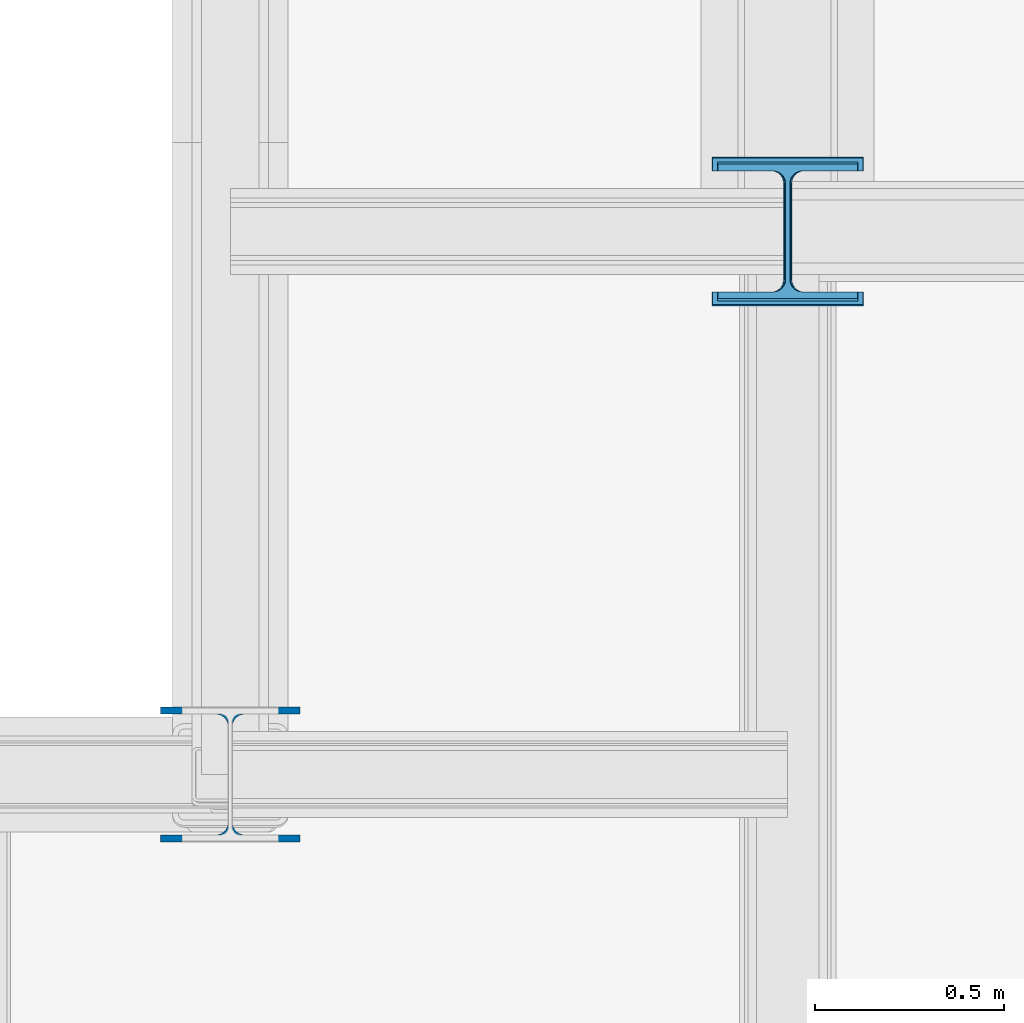
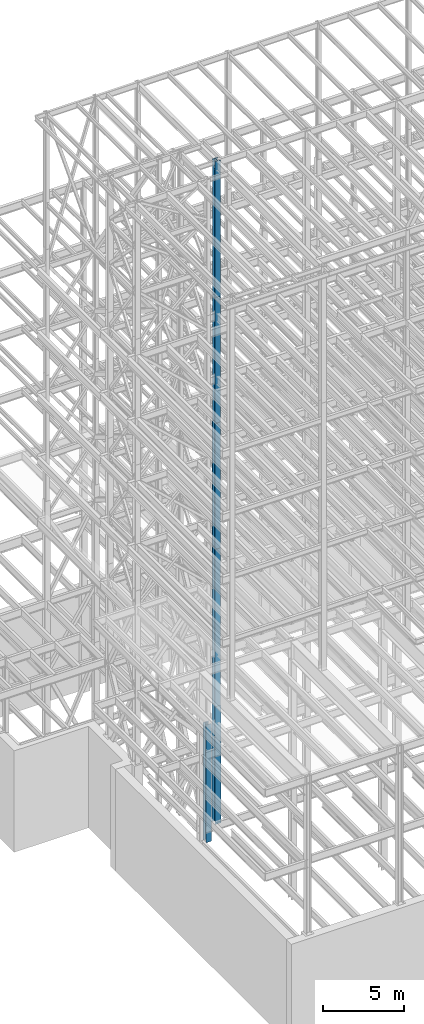
# One storey, part 12 of 150: 6 columns.
"""IFC2X3 building model written with IfcOpenShell, lengths in millimetres."""

from ifc_helpers import new_model, si_unit, frame, origin_with_axes, origin_2d_with_axis, place, context, subcontext, project, spatial, i_section, extrude, material, type_object, element, save


model = new_model("IFC2X3")

# Units and contexts
model_context = context("Model", 3, precision=1e-05, world=origin_with_axes())
body_context = subcontext(model_context, "Body", "Model", "MODEL_VIEW")
ifc_project = project(units=[si_unit("LENGTHUNIT", "METRE", prefix="MILLI"), si_unit("AREAUNIT", "SQUARE_METRE"), si_unit("VOLUMEUNIT", "CUBIC_METRE"), si_unit("MASSUNIT", "GRAM", prefix="KILO"), si_unit("TIMEUNIT", "SECOND"), si_unit("PLANEANGLEUNIT", "RADIAN"), si_unit("SOLIDANGLEUNIT", "STERADIAN"), si_unit("THERMODYNAMICTEMPERATUREUNIT", "DEGREE_CELSIUS"), si_unit("LUMINOUSINTENSITYUNIT", "LUMEN")], contexts=[model_context])

# Site, building, storey
site_placement = place(None, origin_with_axes())
site = spatial("IfcSite", under=ifc_project, at=site_placement, CompositionType="ELEMENT")
building_placement = place(site_placement, origin_with_axes())
building = spatial("IfcBuilding", under=site, at=building_placement, Name="Undefined", CompositionType="ELEMENT")
storey_placement = place(building_placement, origin_with_axes())
storey = spatial("IfcBuildingStorey", under=building, at=storey_placement, Name="Undefined", CompositionType="ELEMENT", Elevation=0.0)

# Columns
ifc_material = material(Name="STEEL/A992")
column_type_1 = type_object("IfcColumnType", Name="W14X193", PredefinedType="NOTDEFINED")
column_1_placement = place(storey_placement, frame((11785.6, 22479.0, 16154.4), z_axis=(0.0, 0.0, 1.0), x_axis=(1.0, 0.0, 0.0)))
element("IfcColumn", 1, at=column_1_placement, inside=storey, type_object=column_type_1, material=ifc_material, Name="COLUMN", ObjectType="W14X193", context=body_context, shape_type="SweptSolid", body=[
    extrude(i_section(OverallWidth=400.05, OverallDepth=393.7, WebThickness=22.225, FlangeThickness=36.576, FilletRadius=33.2739, at=origin_2d_with_axis()), frame((0.0, 0.0, 8839.2), z_axis=(0.0, 0.0, -1.0), x_axis=(-1.0, 0.0, 0.0)), (0.0, 0.0, 1.0), 8839.2),
])
column_type_2 = type_object("IfcColumnType", Name="W14X90", PredefinedType="NOTDEFINED")
column_2_placement = place(storey_placement, frame((11785.6, 22479.0, 55702.2), z_axis=(0.0, 0.0, 1.0), x_axis=(1.0, 0.0, 0.0)))
element("IfcColumn", 2, at=column_2_placement, inside=storey, type_object=column_type_2, material=ifc_material, Name="COLUMN", ObjectType="W14X90", context=body_context, shape_type="SweptSolid", body=[
    extrude(i_section(OverallWidth=368.3, OverallDepth=355.6, WebThickness=11.1125, FlangeThickness=18.034, FilletRadius=32.7659, at=origin_2d_with_axis()), frame((0.0, 0.0, 10210.8), z_axis=(0.0, 0.0, -1.0), x_axis=(-1.0, 0.0, 0.0)), (0.0, 0.0, 1.0), 10210.8),
])
column_3_placement = place(storey_placement, frame((11785.6, 22479.0, 46253.4), z_axis=(0.0, 0.0, 1.0), x_axis=(1.0, 0.0, 0.0)))
element("IfcColumn", 3, at=column_3_placement, inside=storey, type_object=column_type_2, material=ifc_material, Name="COLUMN", ObjectType="W14X90", context=body_context, shape_type="SweptSolid", body=[
    extrude(i_section(OverallWidth=368.3, OverallDepth=355.6, WebThickness=11.1125, FlangeThickness=18.034, FilletRadius=32.7659, at=origin_2d_with_axis()), frame((0.0, 0.0, 9448.8), z_axis=(0.0, 0.0, -1.0), x_axis=(-1.0, 0.0, 0.0)), (0.0, 0.0, 1.0), 9448.8),
])
column_4_placement = place(storey_placement, frame((10312.39949708, 21043.9, 16154.4), z_axis=(0.0, 0.0, 1.0), x_axis=(1.0, 0.0, 0.0)))
element("IfcColumn", 4, at=column_4_placement, inside=storey, type_object=column_type_2, material=ifc_material, Name="COLUMN", ObjectType="W14X90", context=body_context, shape_type="SweptSolid", body=[
    extrude(i_section(OverallWidth=368.3, OverallDepth=355.6, WebThickness=11.1125, FlangeThickness=18.034, FilletRadius=32.7659, at=origin_2d_with_axis()), frame((0.0, 0.0, 8839.2), z_axis=(0.0, 0.0, -1.0), x_axis=(-1.0, 0.0, 0.0)), (0.0, 0.0, 1.0), 8839.2),
])
column_type_3 = type_object("IfcColumnType", Name="W14X120", PredefinedType="NOTDEFINED")
column_5_placement = place(storey_placement, frame((11785.6, 22479.0, 36804.6), z_axis=(0.0, 0.0, 1.0), x_axis=(1.0, 0.0, 0.0)))
element("IfcColumn", 5, at=column_5_placement, inside=storey, type_object=column_type_3, material=ifc_material, Name="COLUMN", ObjectType="W14X120", context=body_context, shape_type="SweptSolid", body=[
    extrude(i_section(OverallWidth=371.475, OverallDepth=368.3, WebThickness=14.2875, FlangeThickness=23.876, FilletRadius=33.274, at=origin_2d_with_axis()), frame((0.0, 0.0, 9448.8), z_axis=(0.0, 0.0, -1.0), x_axis=(-1.0, 0.0, 0.0)), (0.0, 0.0, 1.0), 9448.8),
])
column_type_4 = type_object("IfcColumnType", Name="W14X176", PredefinedType="NOTDEFINED")
column_6_placement = place(storey_placement, frame((11785.6, 22479.0, 24993.6), z_axis=(0.0, 0.0, 1.0), x_axis=(1.0, 0.0, 0.0)))
element("IfcColumn", 6, at=column_6_placement, inside=storey, type_object=column_type_4, material=ifc_material, Name="COLUMN", ObjectType="W14X176", context=body_context, shape_type="SweptSolid", body=[
    extrude(i_section(OverallWidth=396.875, OverallDepth=387.35, WebThickness=20.6375, FlangeThickness=33.274, FilletRadius=33.401, at=origin_2d_with_axis()), frame((0.0, 0.0, 11811.0), z_axis=(0.0, 0.0, -1.0), x_axis=(-1.0, 0.0, 0.0)), (0.0, 0.0, 1.0), 11811.0),
])

save(model, "model.ifc")
